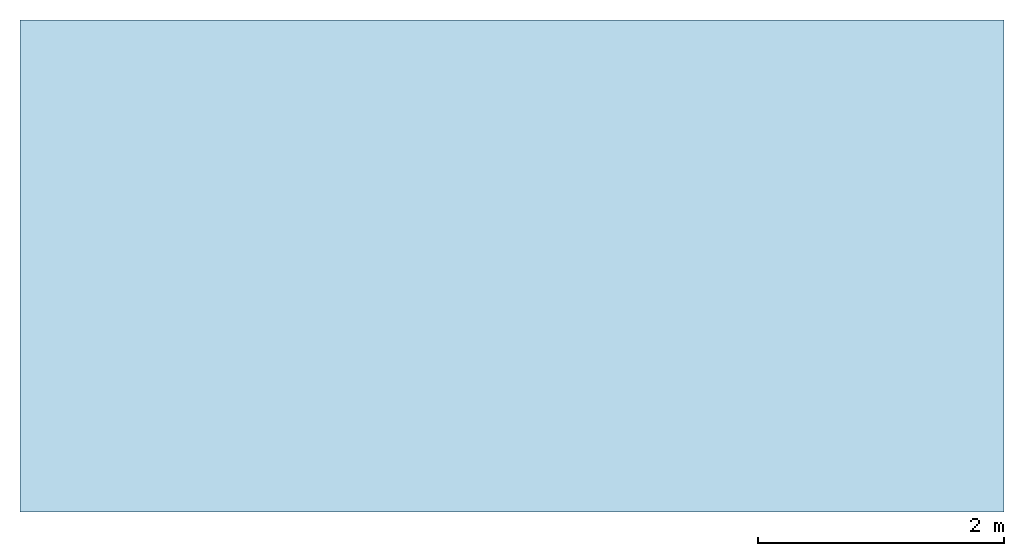
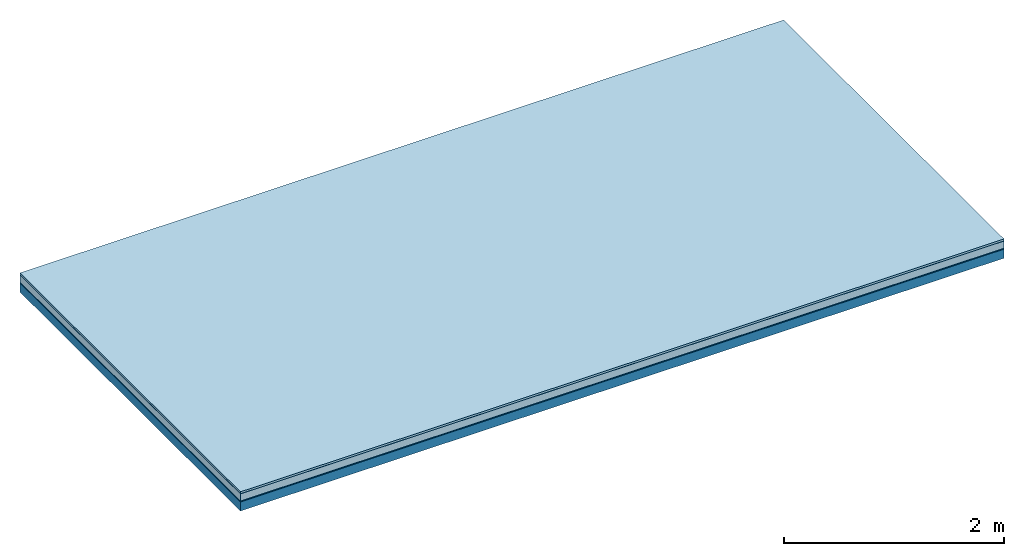
# One storey: 5 plates, 1 member, 1 element without a shape of its own.
"""IFC4 building model written with IfcOpenShell, lengths in metres."""

from ifc_helpers import new_model, si_unit, derived_unit, direction, frame, frame_2d, origin, origin_with_axes, place, context, project, spatial, rectangle, extrude, material, layer, layer_set, type_object, element, aggregate, save


model = new_model("IFC4")

# Units and contexts
plan_context = context("Plan", 3, precision=1e-05, world=origin(), true_north=direction((0.0, 1.0)))
model_context = context("Model", 3, precision=1e-05, world=origin(), true_north=direction((0.0, 1.0)))
ifc_project = project(units=[si_unit("LENGTHUNIT", "METRE"), derived_unit("SOUNDPRESSUREUNIT", [(si_unit("PRESSUREUNIT", "PASCAL", prefix="MICRO"), 0)]), si_unit("ENERGYUNIT", "JOULE", prefix="MEGA"), si_unit("MASSUNIT", "GRAM", prefix="KILO"), derived_unit("THERMALTRANSMITTANCEUNIT", [(si_unit("POWERUNIT", "WATT"), 1), (si_unit("AREAUNIT", "SQUARE_METRE"), -1), (si_unit("THERMODYNAMICTEMPERATUREUNIT", "KELVIN"), -1)]), derived_unit("AREADENSITYUNIT", [(si_unit("MASSUNIT", "GRAM", prefix="KILO"), 1), (si_unit("AREAUNIT", "SQUARE_METRE"), -1)]), derived_unit("USERDEFINED", [(si_unit("ENERGYUNIT", "JOULE", prefix="MEGA"), 1), (si_unit("AREAUNIT", "SQUARE_METRE"), -1)])], contexts=[plan_context, model_context])

# Site, building, storey
site = spatial("IfcSite", under=ifc_project)
building_placement = place(None, origin())
building = spatial("IfcBuilding", under=site, at=building_placement)
storey_placement = place(building_placement, origin())
storey = spatial("IfcBuildingStorey", under=building, at=storey_placement)

# Slab, member, plates
ifc_material_1 = material(Name="with tongue and groove", Category="07.009")
ifc_layer_1 = layer(ifc_material_1, 0.022, Name="Flooring")
ifc_material_2 = material(Category="09.006")
ifc_layer_2 = layer(ifc_material_2, 0.0005, Name="layer")
ifc_material_3 = material(Category="07.011")
ifc_layer_3 = layer(ifc_material_3, 0.08, Name="On-material")
ifc_material_4 = material(Name="Wood fiber generic product", Category="10.009")
ifc_layer_4 = layer(ifc_material_4, 0.01, Name="Impact sound insulation")
ifc_material_5 = material(Name="protection", Category="09.007")
ifc_layer_5 = layer(ifc_material_5, 0.0005, Name="Sub-floor")
ifc_material_6 = material(Name="no composite action")
ifc_layer_6 = layer(ifc_material_6, 0.0, Name="Bond")
ifc_layer_7 = layer(None, 0.1, Name="Supporting structure")
ifc_layer_set = layer_set([ifc_layer_1, ifc_layer_2, ifc_layer_3, ifc_layer_4, ifc_layer_5, ifc_layer_6, ifc_layer_7])
slab_type = type_object("IfcSlabType", Name="A2014", PredefinedType="NOTDEFINED", material=ifc_layer_set)
slab_placement = place(None, frame((0.0, 0.0, 0.0), z_axis=(0.0, 0.0, -1.0), x_axis=(1.0, 0.0, 0.0)))
slab = element("IfcSlab", 1, at=slab_placement, inside=storey, type_object=slab_type, material=ifc_layer_set, Name="Slab #1")
ifc_material_7 = material(Name="Solid timber panel")
member_placement = place(slab_placement, origin())
member = element("IfcMember", 2, at=member_placement, material=ifc_material_7, Name="Supporting structure", context=plan_context, shape_type="SweptSolid", body=[
    extrude(rectangle(XDim=1.0, YDim=0.1, at=frame_2d((0.5, 0.05), x_axis=(1.0, 0.0))), frame((0.0, 4.0, 0.113), z_axis=(0.0, -1.0, 0.0), x_axis=(1.0, 0.0, 0.0)), (0.0, 0.0, 1.0), 4.0),
    extrude(rectangle(XDim=1.0, YDim=0.1, at=frame_2d((0.5, 0.05), x_axis=(1.0, 0.0))), frame((1.0, 4.0, 0.113), z_axis=(0.0, -1.0, 0.0), x_axis=(1.0, 0.0, 0.0)), (0.0, 0.0, 1.0), 4.0),
    extrude(rectangle(XDim=1.0, YDim=0.1, at=frame_2d((0.5, 0.05), x_axis=(1.0, 0.0))), frame((2.0, 4.0, 0.113), z_axis=(0.0, -1.0, 0.0), x_axis=(1.0, 0.0, 0.0)), (0.0, 0.0, 1.0), 4.0),
    extrude(rectangle(XDim=1.0, YDim=0.1, at=frame_2d((0.5, 0.05), x_axis=(1.0, 0.0))), frame((3.0, 4.0, 0.113), z_axis=(0.0, -1.0, 0.0), x_axis=(1.0, 0.0, 0.0)), (0.0, 0.0, 1.0), 4.0),
    extrude(rectangle(XDim=1.0, YDim=0.1, at=frame_2d((0.5, 0.05), x_axis=(1.0, 0.0))), frame((4.0, 4.0, 0.113), z_axis=(0.0, -1.0, 0.0), x_axis=(1.0, 0.0, 0.0)), (0.0, 0.0, 1.0), 4.0),
    extrude(rectangle(XDim=1.0, YDim=0.1, at=frame_2d((0.5, 0.05), x_axis=(1.0, 0.0))), frame((5.0, 4.0, 0.113), z_axis=(0.0, -1.0, 0.0), x_axis=(1.0, 0.0, 0.0)), (0.0, 0.0, 1.0), 4.0),
    extrude(rectangle(XDim=1.0, YDim=0.1, at=frame_2d((0.5, 0.05), x_axis=(1.0, 0.0))), frame((6.0, 4.0, 0.113), z_axis=(0.0, -1.0, 0.0), x_axis=(1.0, 0.0, 0.0)), (0.0, 0.0, 1.0), 4.0),
    extrude(rectangle(XDim=1.0, YDim=0.1, at=frame_2d((0.5, 0.05), x_axis=(1.0, 0.0))), frame((7.0, 4.0, 0.113), z_axis=(0.0, -1.0, 0.0), x_axis=(1.0, 0.0, 0.0)), (0.0, 0.0, 1.0), 4.0),
])
plate_1_placement = place(slab_placement, origin())
plate_1 = element("IfcPlate", 3, at=plate_1_placement, material=ifc_material_1, Name="Flooring", context=plan_context, shape_type="SweptSolid", body=[
    extrude(rectangle(XDim=8.0, YDim=4.0, at=frame_2d((4.0, 2.0), x_axis=(1.0, 0.0))), origin_with_axes(), (0.0, 0.0, 1.0), 0.022),
])
plate_2_placement = place(slab_placement, origin())
plate_2 = element("IfcPlate", 4, at=plate_2_placement, material=ifc_material_2, Name="layer", context=plan_context, shape_type="SweptSolid", body=[
    extrude(rectangle(XDim=8.0, YDim=4.0, at=frame_2d((4.0, 2.0), x_axis=(1.0, 0.0))), frame((0.0, 0.0, 0.022), z_axis=(0.0, 0.0, 1.0), x_axis=(1.0, 0.0, 0.0)), (0.0, 0.0, 1.0), 0.0005),
])
plate_3_placement = place(slab_placement, origin())
plate_3 = element("IfcPlate", 5, at=plate_3_placement, material=ifc_material_3, Name="On-material", context=plan_context, shape_type="SweptSolid", body=[
    extrude(rectangle(XDim=8.0, YDim=4.0, at=frame_2d((4.0, 2.0), x_axis=(1.0, 0.0))), frame((0.0, 0.0, 0.0225), z_axis=(0.0, 0.0, 1.0), x_axis=(1.0, 0.0, 0.0)), (0.0, 0.0, 1.0), 0.08),
])
plate_4_placement = place(slab_placement, origin())
plate_4 = element("IfcPlate", 6, at=plate_4_placement, material=ifc_material_4, Name="Impact sound insulation", context=plan_context, shape_type="SweptSolid", body=[
    extrude(rectangle(XDim=8.0, YDim=4.0, at=frame_2d((4.0, 2.0), x_axis=(1.0, 0.0))), frame((0.0, 0.0, 0.1025), z_axis=(0.0, 0.0, 1.0), x_axis=(1.0, 0.0, 0.0)), (0.0, 0.0, 1.0), 0.01),
])
plate_5_placement = place(slab_placement, origin())
plate_5 = element("IfcPlate", 7, at=plate_5_placement, material=ifc_material_5, Name="Sub-floor", context=plan_context, shape_type="SweptSolid", body=[
    extrude(rectangle(XDim=8.0, YDim=4.0, at=frame_2d((4.0, 2.0), x_axis=(1.0, 0.0))), frame((0.0, 0.0, 0.1125), z_axis=(0.0, 0.0, 1.0), x_axis=(1.0, 0.0, 0.0)), (0.0, 0.0, 1.0), 0.0005),
])
aggregate(slab, [plate_1, plate_2, plate_3, plate_4, plate_5, member])

save(model, "model.ifc")
